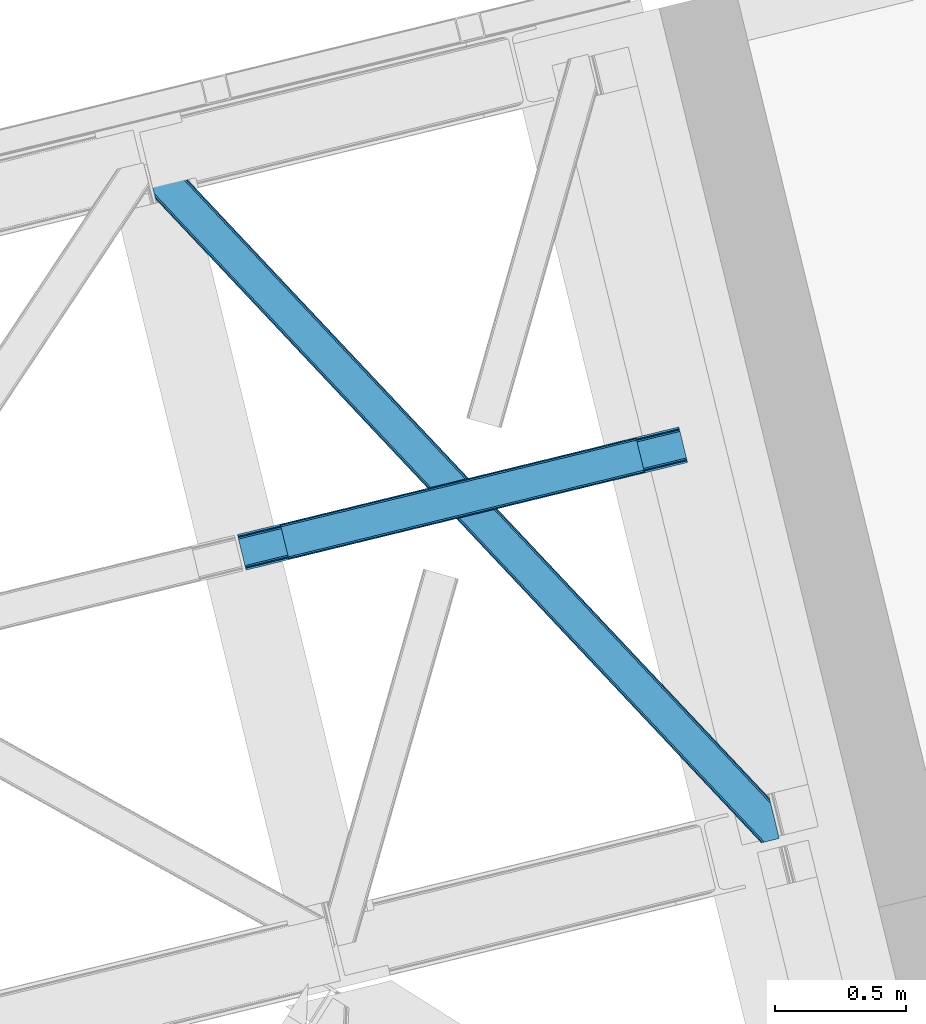
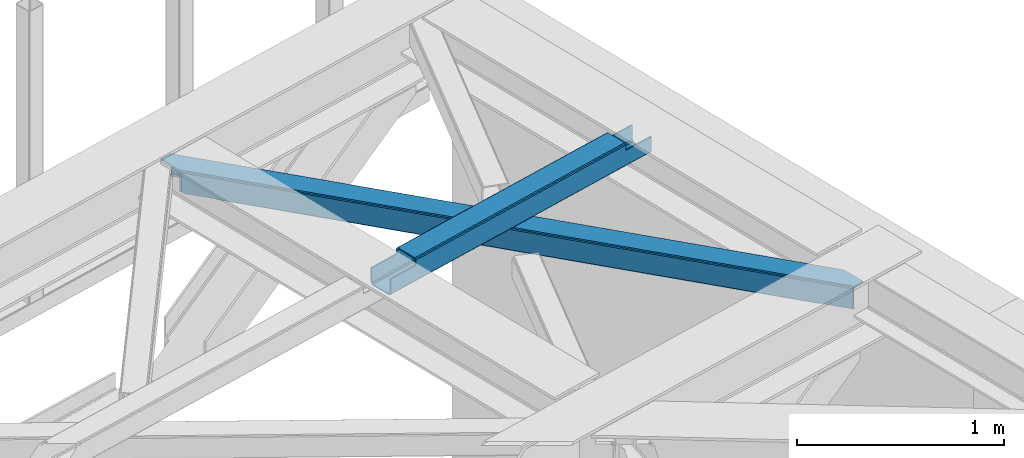
# One storey, part 61 of 66: 1 beam, 1 member.
"""IFC4 building model written with IfcOpenShell, lengths in millimetres."""

import ifcopenshell
import ifcopenshell.guid

model = None  # the IFC model being written
_history = None  # IfcOwnerHistory: only IFC2X3 demands one
_inside = {}  # id of a spatial element -> (the spatial element, [elements in it])
_under = {}  # id of a project, library or spatial element -> (it, [spatial elements below it])
_declared = {}  # id of a project -> (the project, [libraries it declares])
_typed = {}  # id of a type object -> (the type object, [elements of that type])
_made_of = {}  # id of a material, layer set ... -> (it, [elements and type objects made of it])


def new_model(schema):
    """Start an empty IFC model of exactly this schema.

    Asked for "IFC4X3", IfcOpenShell would pick the latest addendum, in which some entities
    have other attributes; the version numbers below select the first issue.
    IFC2X3 requires an IfcOwnerHistory on every rooted entity: one is made here for all.
    """
    global model, _history
    if schema == "IFC4X3":
        model = ifcopenshell.file(schema_version=(4, 3, 0, 0))
    else:
        model = ifcopenshell.file(schema=schema)
    _inside.clear()
    _under.clear()
    _declared.clear()
    _typed.clear()
    _made_of.clear()
    _history = None
    if model.schema == "IFC2X3":
        org = make("IfcOrganization", Name="unknown")
        user = make(
            "IfcPersonAndOrganization",
            ThePerson=make("IfcPerson", FamilyName="unknown"),
            TheOrganization=org,
        )
        app = make(
            "IfcApplication",
            ApplicationDeveloper=org,
            Version="unknown",
            ApplicationFullName="unknown",
            ApplicationIdentifier="unknown",
        )
        _history = make(
            "IfcOwnerHistory",
            OwningUser=user,
            OwningApplication=app,
            ChangeAction="ADDED",
            CreationDate=0,
        )
    return model


def make(cls, **values):
    """One entity of the class cls with the attributes given. An attribute that is None is left unset."""
    return model.create_entity(
        cls, **{name: value for name, value in values.items() if value is not None}
    )


def entity(cls, *values):
    """Any entity or typed value of the class cls, its attributes in the order of the schema. None: left unset."""
    e = model.create_entity(cls)
    for i, value in enumerate(values):
        if value is not None:
            e[i] = value
    return e


def rooted(cls, **values):
    """An entity with a GlobalId (a new one), such as an element, a storey or a relation."""
    return make(cls, GlobalId=ifcopenshell.guid.new(), OwnerHistory=_history, **values)


def si_unit(unit_type, name, prefix=None):
    """IfcSIUnit, for example si_unit("LENGTHUNIT", "METRE", prefix="MILLI")."""
    return make("IfcSIUnit", UnitType=unit_type, Prefix=prefix, Name=name)


def converted_unit(unit_type, name, factor, base, dimensions=None, offset=None):
    """IfcConversionBasedUnit, such as the inch: factor (a typed value) times the base unit."""
    return make(
        "IfcConversionBasedUnit"
        if offset is None
        else "IfcConversionBasedUnitWithOffset",
        ConversionOffset=offset,
        Dimensions=None
        if dimensions is None
        else entity("IfcDimensionalExponents", *dimensions),
        UnitType=unit_type,
        Name=name,
        ConversionFactor=make(
            "IfcMeasureWithUnit", ValueComponent=factor, UnitComponent=base
        ),
    )


def derived_unit(unit_type, elements):
    """IfcDerivedUnit: a product of units, each with its exponent."""
    return make(
        "IfcDerivedUnit",
        Elements=[
            make("IfcDerivedUnitElement", Unit=unit, Exponent=power)
            for unit, power in elements
        ],
        UnitType=unit_type,
    )


def assignment(units):
    """IfcUnitAssignment: the units of a project."""
    return None if units is None else make("IfcUnitAssignment", Units=units)


def point(xyz):
    """IfcCartesianPoint."""
    return None if xyz is None else make("IfcCartesianPoint", Coordinates=xyz)


def direction(xyz):
    """IfcDirection."""
    return None if xyz is None else make("IfcDirection", DirectionRatios=xyz)


def frame(location, z_axis=None, x_axis=None):
    """IfcAxis2Placement3D, a coordinate frame: its origin and axes. An axis left out is left unset."""
    return make(
        "IfcAxis2Placement3D",
        Location=point(location),
        Axis=direction(z_axis),
        RefDirection=direction(x_axis),
    )


def origin():
    """The frame at (0, 0, 0) with its axes left unset."""
    return frame((0.0, 0.0, 0.0))


def place(relative_to, where):
    """IfcLocalPlacement: puts the frame where relative to a parent placement (None: the world)."""
    return make(
        "IfcLocalPlacement", PlacementRelTo=relative_to, RelativePlacement=where
    )


def context(
    kind, dimensions, precision=None, world=None, true_north=None, identifier=None
):
    """IfcGeometricRepresentationContext, for example the 3D "Model" context."""
    return make(
        "IfcGeometricRepresentationContext",
        ContextIdentifier=identifier,
        ContextType=kind,
        CoordinateSpaceDimension=dimensions,
        Precision=precision,
        WorldCoordinateSystem=world,
        TrueNorth=true_north,
    )


def subcontext(parent, identifier, kind, view, scale=None):
    """IfcGeometricRepresentationSubContext, for example "Body" below "Model"."""
    return make(
        "IfcGeometricRepresentationSubContext",
        ContextIdentifier=identifier,
        ContextType=kind,
        ParentContext=parent,
        TargetScale=scale,
        TargetView=view,
    )


def project(units=None, contexts=None):
    """IfcProject with its units and contexts."""
    return rooted(
        "IfcProject",
        Name="project",
        RepresentationContexts=contexts,
        UnitsInContext=assignment(units),
    )


def spatial(cls, under=None, at=None, **own):
    """A site, building, storey or space (cls), placed at a placement, below another one or the project."""
    s = rooted(cls, ObjectPlacement=at, **own)
    if under is not None:
        _under.setdefault(under.id(), (under, []))[1].append(s)
    return s


def point_list(points):
    """IfcCartesianPointList2D or 3D."""
    cls = (
        "IfcCartesianPointList2D" if len(points[0]) == 2 else "IfcCartesianPointList3D"
    )
    return make(cls, CoordList=points)


def triangles(points, corners, closed=None, point_numbers=None):
    """IfcTriangulatedFaceSet: each triangle names its three corners, points numbered from 1."""
    return make(
        "IfcTriangulatedFaceSet",
        Coordinates=point_list(points),
        Closed=closed,
        CoordIndex=corners,
        PnIndex=point_numbers,
    )


def polygons(points, faces, closed=None, point_numbers=None):
    """IfcPolygonalFaceSet: a face is its outer loop, then its inner loops; points numbered from 1."""
    made = []
    for loops in faces:
        if len(loops) == 1:
            made.append(make("IfcIndexedPolygonalFace", CoordIndex=loops[0]))
        else:
            made.append(
                make(
                    "IfcIndexedPolygonalFaceWithVoids",
                    CoordIndex=loops[0],
                    InnerCoordIndices=loops[1:],
                )
            )
    return make(
        "IfcPolygonalFaceSet",
        Coordinates=point_list(points),
        Closed=closed,
        Faces=made,
        PnIndex=point_numbers,
    )


def shape(context_of_items, identifier, shape_type, items):
    """IfcShapeRepresentation: the items that make up one representation, for example the "Body"."""
    return make(
        "IfcShapeRepresentation",
        ContextOfItems=context_of_items,
        RepresentationIdentifier=identifier,
        RepresentationType=shape_type,
        Items=items,
    )


def material(Name=None, Category=None):
    """IfcMaterial."""
    return make("IfcMaterial", Name=Name, Category=Category)


def made_of(thing, what):
    """Note that an element or type object is made of a material, layer set ...; save() writes the relation."""
    if what is not None:
        _made_of.setdefault(what.id(), (what, []))[1].append(thing)
    return thing


def type_object(cls, material=None, **own):
    """A type object (cls), such as IfcWallType, which elements share."""
    return made_of(rooted(cls, **own), material)


def element(
    cls,
    number,
    at=None,
    inside=None,
    cuts=None,
    type_object=None,
    material=None,
    context=None,
    identifier="Body",
    shape_type=None,
    held_by="IfcProductDefinitionShape",
    body=None,
    shapes=None,
    **own,
):
    """One element of the class cls, such as IfcWall. Its Tag is "e" and its number.

    at: its placement. inside: the storey or other place that contains it. cuts: it is an
    opening in that element (IfcRelVoidsElement). A single representation is given by context,
    identifier, shape_type and body (its items); several are given by shapes. held_by: the class
    of the entity that holds the representations. save() writes the other relations.
    """
    e = rooted(cls, Tag="e%d" % number, ObjectPlacement=at, **own)
    if body is not None:
        shapes = [shape(context, identifier, shape_type, body)]
    if shapes is not None:
        e.Representation = make(held_by, Representations=shapes)
    if inside is not None:
        _inside.setdefault(inside.id(), (inside, []))[1].append(e)
    if cuts is not None:
        rooted(
            "IfcRelVoidsElement", RelatingBuildingElement=cuts, RelatedOpeningElement=e
        )
    if type_object is not None:
        _typed.setdefault(type_object.id(), (type_object, []))[1].append(e)
    return made_of(e, material)


def aggregate(whole, parts):
    """IfcRelAggregates: a whole, such as a stair, and the parts it consists of."""
    return rooted("IfcRelAggregates", RelatingObject=whole, RelatedObjects=parts)


def save(model, path):
    """Write the relations noted so far, then the file.

    IfcRelAggregates (storeys below a building ...), IfcRelContainedInSpatialStructure (elements
    in a storey), IfcRelDefinesByType, IfcRelAssociatesMaterial and IfcRelDeclares: one each for
    every whole, place, type object, material and project.
    """
    for whole, parts in _under.values():
        aggregate(whole, parts)
    for where, things in _inside.values():
        rooted(
            "IfcRelContainedInSpatialStructure",
            RelatedElements=things,
            RelatingStructure=where,
        )
    for kind, things in _typed.values():
        rooted("IfcRelDefinesByType", RelatedObjects=things, RelatingType=kind)
    for what, things in _made_of.values():
        rooted("IfcRelAssociatesMaterial", RelatedObjects=things, RelatingMaterial=what)
    for by, libraries in _declared.values():
        rooted("IfcRelDeclares", RelatingContext=by, RelatedDefinitions=libraries)
    model.write(path)


model = new_model("IFC4")

# Units and contexts
model_context = context("Model", 3, precision=0.01, world=origin(), true_north=direction((6.12303176911189e-17, 1.0)))
plan_context = context("Plan", 3, precision=0.01, world=origin(), true_north=direction((6.12303176911189e-17, 1.0)))
body_context = subcontext(model_context, "Body", "Model", "MODEL_VIEW")
ifc_project = project(units=[si_unit("LENGTHUNIT", "METRE", prefix="MILLI"), si_unit("AREAUNIT", "SQUARE_METRE"), si_unit("VOLUMEUNIT", "CUBIC_METRE"), converted_unit("PLANEANGLEUNIT", "DEGREE", entity("IfcRatioMeasure", 0.0174532925199433), si_unit("PLANEANGLEUNIT", "RADIAN"), dimensions=[0, 0, 0, 0, 0, 0, 0]), si_unit("MASSUNIT", "GRAM", prefix="KILO"), derived_unit("MASSDENSITYUNIT", [(si_unit("MASSUNIT", "GRAM", prefix="KILO"), 1), (si_unit("LENGTHUNIT", "METRE"), -3)]), derived_unit("MOMENTOFINERTIAUNIT", [(si_unit("LENGTHUNIT", "METRE"), 4)]), si_unit("TIMEUNIT", "SECOND"), si_unit("FREQUENCYUNIT", "HERTZ"), si_unit("THERMODYNAMICTEMPERATUREUNIT", "DEGREE_CELSIUS"), derived_unit("THERMALTRANSMITTANCEUNIT", [(si_unit("MASSUNIT", "GRAM", prefix="KILO"), 1), (si_unit("THERMODYNAMICTEMPERATUREUNIT", "KELVIN"), -1), (si_unit("TIMEUNIT", "SECOND"), -3)]), derived_unit("VOLUMETRICFLOWRATEUNIT", [(si_unit("LENGTHUNIT", "METRE"), 3), (si_unit("TIMEUNIT", "SECOND"), -1)]), derived_unit("MASSFLOWRATEUNIT", [(si_unit("MASSUNIT", "GRAM", prefix="KILO"), 1), (si_unit("TIMEUNIT", "SECOND"), -1)]), derived_unit("ROTATIONALFREQUENCYUNIT", [(si_unit("TIMEUNIT", "SECOND"), -1)]), si_unit("ELECTRICCURRENTUNIT", "AMPERE"), si_unit("ELECTRICVOLTAGEUNIT", "VOLT"), si_unit("POWERUNIT", "WATT"), si_unit("FORCEUNIT", "NEWTON", prefix="KILO"), si_unit("ILLUMINANCEUNIT", "LUX"), si_unit("LUMINOUSFLUXUNIT", "LUMEN"), si_unit("LUMINOUSINTENSITYUNIT", "CANDELA"), derived_unit("USERDEFINED", [(si_unit("MASSUNIT", "GRAM", prefix="KILO"), -1), (si_unit("LENGTHUNIT", "METRE"), -2), (si_unit("TIMEUNIT", "SECOND"), 3), (si_unit("LUMINOUSFLUXUNIT", "LUMEN"), 1)]), derived_unit("LINEARVELOCITYUNIT", [(si_unit("LENGTHUNIT", "METRE"), 1), (si_unit("TIMEUNIT", "SECOND"), -1)]), si_unit("PRESSUREUNIT", "PASCAL"), derived_unit("USERDEFINED", [(si_unit("LENGTHUNIT", "METRE"), -2), (si_unit("MASSUNIT", "GRAM", prefix="KILO"), 1), (si_unit("TIMEUNIT", "SECOND"), -2)]), derived_unit("LINEARFORCEUNIT", [(si_unit("MASSUNIT", "GRAM", prefix="KILO"), 1), (si_unit("LENGTHUNIT", "METRE"), 1), (si_unit("TIMEUNIT", "SECOND"), -2), (si_unit("LENGTHUNIT", "METRE"), -1)]), derived_unit("PLANARFORCEUNIT", [(si_unit("MASSUNIT", "GRAM", prefix="KILO"), 1), (si_unit("LENGTHUNIT", "METRE"), 1), (si_unit("TIMEUNIT", "SECOND"), -2), (si_unit("LENGTHUNIT", "METRE"), -2)])], contexts=[model_context, plan_context])

# Site, building, storey
site_placement = place(None, origin())
site = spatial("IfcSite", under=ifc_project, at=site_placement, CompositionType="ELEMENT")
building_placement = place(site_placement, origin())
building = spatial("IfcBuilding", under=site, at=building_placement, CompositionType="ELEMENT")
storey_placement = place(building_placement, frame((0.0, 0.0, 19800.0)))
storey = spatial("IfcBuildingStorey", under=building, at=storey_placement, Name="06", CompositionType="ELEMENT", Elevation=19800.0)

# Beam
ifc_material = material(Name="Metal painted (White)")
beam_type = type_object("IfcBeamType", PredefinedType="BEAM")
beam_placement = place(storey_placement, frame((-2546.54, 18519.2, 3967.02)))
element("IfcBeam", 1, at=beam_placement, inside=storey, type_object=beam_type, material=ifc_material, ObjectType="Steel Beam", PredefinedType="BEAM", context=body_context, shape_type="Tessellation", body=[
    polygons([(31.1823923917663, 8.09507685196325, 17.8030399336114), (31.4978703677219, 6.80086440699217, 24.4999999999988), (1720.05534741759, 418.404614024197, 24.4999999999988), (1719.73986944163, 419.698826469164, 17.8030399336114), (30.2839871259127, 11.7806820741907, 12.1256313292298), (1718.84146417578, 423.384431691391, 12.1256313292298), (28.9394286278299, 17.2965800886753, 8.33210818105214), (1717.4969056777, 428.90032970588, 8.33210818105214), (27.3534137403943, 23.8030254244683, 7.00000000000274), (1715.91089079026, 435.406775041673, 7.00000000000274), (4.21622439083855, 118.720708051134, 8.33210818105214), (5.80223927827368, 112.214262715343, 7.00000000000274), (1694.35971632814, 523.818012332546, 7.00000000000274), (1692.77370144071, 530.324457668336, 8.33210818105214), (2.87166589275528, 124.236606065622, 12.1256313292342), (1691.42914294262, 535.840355682825, 12.1256313292342), (1.97326062690218, 127.922211287848, 17.8030399336114), (1690.53073767677, 539.525960905051, 17.8030399336114), (1.65778265093897, 129.216423732819, 24.4999999999988), (1690.2152597008, 540.820173350022, 24.4999999999988), (33.1556530186512, 2.16573425859679e-12, 17.5000000000004), (33.155653018649, 0.0, 99.499999999999), (31.4978703677154, 6.80086440699217, 99.499999999999), (1.65778265093518, 129.216423732817, 99.499999999999), (2.70716782324598e-12, 136.017288139807, 99.499999999999), (3.79003495254437e-12, 136.017288139809, 17.5000000000004), (0.315477975962668, 134.72307569484, 10.803039933613), (1.21388324181576, 131.037470472615, 5.12563132923143), (2.55844173989904, 125.521572458126, 1.33210818105373), (4.14445662733417, 119.015127122333, 0.0), (29.0111963913197, 17.0021610174783, 0.0), (30.5972112787548, 10.4957156816875, 1.33210818105373), (31.9417697768392, 4.97981766719418, 5.12563132923576), (32.8401750426917, 1.29421244497107, 10.803039933613), (1688.55747704987, 547.62103775701, 17.5000000000004), (1688.55747704987, 547.62103775701, 99.499999999999), (1690.2152597008, 540.820173350022, 99.499999999999), (1720.05534741758, 418.404614024193, 99.499999999999), (1721.71313006851, 411.603749617205, 99.499999999999), (1721.71313006851, 411.603749617205, 17.5000000000004), (1721.39765209255, 412.897962062172, 10.803039933613), (1720.4992468267, 416.583567284397, 5.12563132923576), (1719.15468832862, 422.099465298888, 1.33210818105373), (1717.56867344118, 428.605910634677, 0.0), (1692.7019336772, 530.618876739533, 0.0), (1691.11591878976, 537.125322075326, 1.33210818105373), (1689.77136029168, 542.641220089815, 5.12563132923143), (1688.87295502583, 546.326825312043, 10.803039933613), (1555.87153982994, 378.383074424505, 115.5000123926), (1555.92790791481, 378.396813643123, 100.117303289864), (1556.83460164982, 378.617830401818, 99.499999999999), (194.718606580802, 46.5876811586757, 99.5063429816656), (195.631369831917, 46.8101414945073, 100.117301735448), (195.69016819363, 46.824474122359, 115.5), (1558.49238430075, 371.81696599483, 99.499999999999), (1557.58582420851, 371.595981821318, 100.117303484932), (1557.52624144083, 371.581458788976, 122.500007895425), (197.345360928056, 40.0229783796067, 122.500002534479), (197.338587096744, 40.0213271441522, 100.500009163303), (196.748205195733, 39.8773799905108, 99.5697919021647), (1526.99452348773, 501.033356598336, 99.5063429816656), (1526.08541462826, 500.811786435622, 100.117299778624), (1526.02904654339, 500.798047217008, 115.50000888136), (165.85008047685, 169.240033448186, 115.5), (165.840462203346, 169.237688832046, 100.50000941238), (165.250325295043, 169.093836777335, 99.5761204674868), (1524.96492487281, 507.743657766505, 99.5697919021647), (163.22074576778, 175.804071762184, 99.499999999999), (164.133244938524, 176.026503182401, 100.117301984524), (164.18943998764, 176.04020120897, 122.500002796667), (1524.36791556689, 507.598095225085, 122.500003994045), (1524.37801885572, 507.600558639654, 100.500018741102), (1524.68002972126, 506.303062602923, 129.196959150505), (1525.57336524685, 502.616221261231, 134.874360354937), (1526.91465625092, 497.099526556424, 138.667878733795), (1528.49970333692, 490.592845248349, 139.999985502214), (1553.37045238386, 388.580856699036, 139.999991354279), (1554.95794650144, 382.074772033634, 138.667885332354), (1556.30620606188, 376.559776423407, 134.874367586349), (1557.20997076909, 372.875477956454, 129.196966804773), (1555.55835019824, 379.677844820524, 122.196975799125), (1554.65458549103, 383.362143287481, 127.874376580702), (1553.3063259306, 388.877138897706, 131.667894326702), (1551.71883181301, 395.383223563109, 133.000000348631), (1530.164182639, 483.793613639179, 132.999995276841), (1528.579135553, 490.300294947254, 131.667888508414), (1527.23784454893, 495.816989652061, 127.874370129564), (1526.34450902334, 499.503830993753, 122.196968925133), (164.878528418712, 169.003207355194, 99.499999999999), (193.131726453735, 57.3201898040421, 131.667891818946), (191.5457115663, 63.826635139835, 133.0), (194.476284951818, 51.8042917895531, 127.874368670764), (195.374690217671, 48.1186865673279, 122.196960066391), (169.994537104178, 152.237872430709, 133.0), (166.165558452807, 167.945821003219, 122.196960066391), (167.06396371866, 164.260215780991, 127.874368670764), (168.408522216743, 158.744317766505, 131.667891818946), (197.031411944076, 41.3175635421181, 129.196961104604), (196.136488323068, 45.0040174739068, 134.874366301861), (194.794244157318, 50.5204796458773, 138.667887185257), (193.209023953587, 57.0271186992037, 139.999994588639), (168.341882306944, 159.039986838394, 139.999994981919), (166.755021471193, 165.546225960036, 138.667887628704), (165.408105180737, 171.061549222932, 134.874366787843), (164.50618923097, 174.746298656831, 129.196961619)], [[[1, 2, 3, 4]], [[5, 1, 4, 6]], [[7, 5, 6, 8]], [[9, 7, 8, 10]], [[11, 12, 13, 14]], [[15, 11, 14, 16]], [[17, 15, 16, 18]], [[19, 17, 18, 20]], [[12, 9, 10, 13]], [[21, 22, 23, 2, 1, 5, 7, 9, 12, 11, 15, 17, 19, 24, 25, 26, 27, 28, 29, 30, 31, 32, 33, 34]], [[35, 36, 37, 20, 18, 16, 14, 13, 10, 8, 6, 4, 3, 38, 39, 40, 41, 42, 43, 44, 45, 46, 47, 48]], [[49, 50, 51, 38, 3, 2, 23, 52, 53, 54]], [[55, 39, 38, 51]], [[39, 55, 56, 57, 58, 59, 60, 22, 21, 40]], [[32, 31, 44, 43]], [[33, 32, 43, 42]], [[34, 33, 42, 41]], [[21, 34, 41, 40]], [[31, 30, 45, 44]], [[27, 26, 35, 48]], [[28, 27, 48, 47]], [[29, 28, 47, 46]], [[30, 29, 46, 45]], [[20, 37, 61, 62, 63, 64, 65, 66, 24, 19]], [[67, 36, 35, 26, 25, 68, 69, 70, 71, 72]], [[36, 67, 61, 37]], [[72, 71, 73, 74, 75, 76, 77, 78, 79, 80, 57, 56, 50, 49, 81, 82, 83, 84, 85, 86, 87, 88, 63, 62]], [[60, 52, 23, 22]], [[25, 24, 89, 68]], [[90, 91, 84, 83]], [[92, 90, 83, 82]], [[93, 92, 82, 81]], [[54, 93, 81, 49]], [[94, 85, 84, 91]], [[95, 64, 63, 88]], [[96, 95, 88, 87]], [[97, 96, 87, 86]], [[94, 97, 86, 85]], [[65, 64, 95, 96, 97, 94, 91, 90, 92, 93, 54, 53, 59, 58, 98, 99, 100, 101, 102, 103, 104, 105, 70, 69]], [[98, 58, 57, 80]], [[99, 98, 80, 79]], [[100, 99, 79, 78]], [[101, 100, 78, 77]], [[77, 76, 102, 101]], [[103, 102, 76, 75]], [[104, 103, 75, 74]], [[105, 104, 74, 73]], [[70, 105, 73, 71]]], closed=False),
])

# Member
member_type = type_object("IfcMemberType", PredefinedType="BRACE")
member_placement = place(storey_placement, frame((-2893.85, 17476.17, 3823.02)))
element("IfcMember", 2, at=member_placement, inside=storey, type_object=member_type, ObjectType="Steel Horizontal Brace", PredefinedType="BRACE", context=body_context, shape_type="Tessellation", body=[
    triangles([(2390.20879182816, 136.983499145506, 139.998431396481), (2386.99318141937, 150.175717163085, 138.668280029295), (56.5227127075195, 2617.59836425781, 139.998431396481), (64.0010353088378, 2619.42150878906, 138.668280029295), (2384.26711235046, 161.358755493166, 134.873162841795), (70.3451248168944, 2620.96792602539, 134.873162841795), (2382.44560289383, 168.831555175781, 129.196765136716), (74.5788780212401, 2622.00042114258, 129.196765136716), (2381.80599803925, 171.455813598634, 122.499499511716), (76.0700660705566, 2622.36318969727, 122.499499511716), (2006.64328708649, 570.234960937501, 17.4989318847656), (2381.80599803925, 171.455813598634, 17.4989318847656), (1617.6124546051, 983.763208007811, 17.4989318847656), (1228.57718925476, 1397.2902923584, 17.4989318847656), (450.510873413086, 2224.3456237793, 17.4989318847656), (76.0700660705566, 2622.36318969727, 17.4989318847656), (839.546284103394, 1810.81853942871, 17.4989318847656), (26.1158477783201, 2496.68248901367, 139.998431396481), (0.0, 2603.82013549805, 139.998431396481), (2370.43223733902, 4.76366271972802, 139.998431396481), (2419.52200984955, 16.7303741455071, 139.998431396481), (2350.88942584991, 0.0, 122.499499511716), (2352.37603569031, 0.362768554688955, 129.196765136716), (34.5188232421874, 2462.2125, 122.499499511716), (33.8790367126462, 2464.83559570312, 129.196765136716), (2356.61443977356, 1.395263671875, 134.873162841795), (32.0576362609863, 2472.30723266601, 134.873162841795), (2362.95402374268, 2.94051818847583, 138.668280029295), (29.3316398620605, 2483.49259643555, 138.668280029295), (1193.06046180725, 1230.72371520996, 17.4989318847656), (1583.89125709534, 815.290933227538, 17.4989318847656), (1974.7174741745, 399.856988525389, 17.4989318847656), (2350.88942584991, 0.0, 17.4989318847656), (802.234317398071, 1646.15765991211, 17.4989318847656), (411.408027648926, 2061.59276733398, 17.4989318847656), (34.5188232421874, 2462.2125, 17.4989318847656), (2364.4315861702, 3.30096130371021, 127.873590087889), (2370.77113380432, 4.84621582031104, 131.666381835938), (2360.19314575195, 2.26730346679688, 122.19719238281), (2378.2538892746, 6.67052307129052, 132.998858642575), (2419.52200984955, 16.7303741455071, 132.998858642575), (2358.70653591156, 1.90569763183521, 115.49992675781), (2358.70653591156, 1.90569763183521, 24.4985046386719), (2360.19314575195, 2.26730346679688, 17.8035644531228), (2352.67877883911, 0.436019897460938, 10.8691040039048), (2353.04928674698, 0.526712036131357, 9.49942016601563), (2364.4315861702, 3.30096130371021, 12.1248413085923), (2368.18651685715, 4.21602172851635, 9.49942016601563), (1982.47063465118, 401.827798461913, 24.4985046386719), (1588.94283828735, 820.135986328125, 24.4985046386719), (1195.4104637146, 1238.44417419434, 24.4985046386719), (31.1576911926268, 2476.00003051758, 115.49992675781), (408.350074768066, 2075.05938720703, 24.4985046386719), (31.1576911926268, 2476.00003051758, 24.4985046386719), (801.882594680786, 1656.75236206055, 24.4985046386719), (25.9705078124998, 2497.28012695313, 131.666381835938), (22.7547157287595, 2510.4723449707, 132.998858642575), (28.6965042114257, 2486.09708862305, 127.873590087889), (30.517904663086, 2478.6231262207, 122.19719238281), (30.3873893737791, 2479.16030273437, 17.8710021972656), (34.5051612854004, 2462.26831054688, 16.4989929199219), (30.22809677124, 2479.8137512207, 16.4989929199219), (0.0, 2603.82013549805, 132.998858642575), (48.7057479858399, 2615.6938293457, 132.998858642575), (2393.56992387772, 123.194805908202, 132.998858642575), (2385.16713008881, 157.66712036133, 115.49992675781), (2385.80673494339, 155.042861938477, 122.19719238281), (66.7619132995605, 2620.09588623047, 122.19719238281), (68.2484504699705, 2620.4563293457, 115.49992675781), (2387.62824440002, 147.570062255858, 127.873590087889), (62.527869415283, 2619.06339111328, 127.873590087889), (2390.35431346893, 136.387023925781, 131.666381835938), (56.1837799072264, 2617.51697387695, 131.666381835938), (1226.23169288635, 1389.57215881348, 24.4985046386719), (1617.96868286133, 973.170831298827, 24.4985046386719), (2009.70560016632, 556.76950378418, 24.4985046386719), (2385.16713008881, 157.66712036133, 24.4985046386719), (834.490197372436, 1805.9723236084, 24.4985046386719), (442.753207397461, 2222.37365112305, 24.4985046386719), (68.2484504699705, 2620.4563293457, 24.4985046386719), (66.7619132995605, 2620.09588623047, 17.8035644531228), (74.2762802124021, 2621.92600708008, 10.8691040039048), (73.9056632995603, 2621.83764038086, 9.49942016601563), (62.527869415283, 2619.06339111328, 12.1248413085923), (58.7728660583493, 2618.14716796875, 9.49942016601563), (2385.9372502327, 154.508010864258, 17.8710021972656), (2386.09654283524, 153.854562377928, 16.4989929199219), (2381.81973266602, 171.398840332033, 16.4989929199219), (41.7939605712891, 2456.42215576172, 10.8016662597656), (36.8073463439941, 2482.3787109375, 9.49942016601563), (34.7757843017575, 2479.63701782226, 12.1248413085923), (43.3136352539063, 2455.68731689453, 9.49942016601563), (170.418958282471, 2340.35482177734, 9.49942016601563), (155.286451721192, 2336.66434936523, 9.49942016601563), (180.780244445801, 2508.2352722168, 9.49942016601563), (187.286533355713, 2481.54155273438, 9.49942016601563), (181.188068389893, 2507.60275268555, 9.25292358398292), (187.878357696533, 2480.72532348633, 9.42268066406177), (181.610426330567, 2506.94930419922, 8.99945068359375), (188.450415802002, 2479.24401855469, 9.11572265625), (182.028424072265, 2506.29585571289, 8.74597778320094), (189.028287506103, 2477.75573730469, 8.80643920898365), (182.436248016357, 2505.66333618164, 8.49948120117188), (189.60005493164, 2476.27443237305, 8.49948120117188), (2381.54910964966, 154.028970336913, 12.1248413085923), (2374.53078804016, 177.24383239746, 10.8016662597656), (2379.51751127243, 151.288439941407, 9.49942016601563), (2373.01111335754, 177.979833984376, 9.49942016601563), (2233.21012630463, 306.80569152832, 9.49942016601563), (2248.34285087585, 310.495001220705, 9.49942016601563), (2005.67379684448, 569.32222595215, 10.8016662597656), (2002.91328220367, 566.723547363283, 5.12526855468604), (2244.78223972321, 309.626449584961, 5.12526855468604), (449.541455841064, 2223.43405151367, 10.8016662597656), (446.776508331299, 2220.83421020508, 5.12526855468604), (183.700996398926, 2500.47295532226, 5.12526855468604), (442.640714263916, 2216.94375, 1.33247680663771), (186.427283477783, 2489.28991699219, 1.33247680663771), (437.765721130371, 2212.35565795899, 0.0), (189.642784881592, 2476.09769897461, 0.0), (2238.43815021515, 308.080032348633, 1.33247680663771), (2230.95990028381, 306.256887817384, 0.0), (1998.77770614624, 562.833087158204, 1.33247680663771), (1993.89820747375, 558.24383239746, 0.0), (1616.64303703308, 982.850473022459, 10.8016662597656), (1227.60762634277, 1396.37755737305, 10.8016662597656), (838.572215652466, 1809.90464172363, 10.8016662597656), (1613.87794418335, 980.250631713869, 5.12526855468604), (1224.84253349304, 1393.77771606445, 5.12526855468604), (835.811773681641, 1807.30596313476, 5.12526855468604), (1609.74229545593, 976.36017150879, 1.33247680663771), (1220.71153564453, 1389.8884185791, 1.33247680663771), (831.676124954224, 1803.41666564941, 1.33247680663771), (1604.86730232239, 971.772079467773, 0.0), (1215.83203697205, 1385.29916381836, 0.0), (826.796626281738, 1798.82741088867, 0.0), (2008.73153171539, 555.855606079102, 17.8035644531228), (2005.9709444046, 553.256927490234, 12.1248413085923), (439.023202514648, 2218.86223754883, 12.1248413085923), (189.798298645019, 2475.46052856445, 8.4111145019524), (434.887699127197, 2214.97177734375, 8.33204956054396), (193.003916931152, 2462.31016845703, 6.99957275390625), (2001.83544101715, 549.366467285156, 8.33204956054396), (1996.95594234467, 544.777212524416, 6.99957275390625), (2223.14279022217, 304.352352905273, 6.99957275390625), (2230.46741580963, 306.137127685546, 8.81806640624927), (430.008055114746, 2210.38368530274, 6.99957275390625), (441.783789825439, 2221.45975341797, 17.8035644531228), (1610.09852371216, 965.767794799805, 8.33204956054396), (1605.21902503967, 961.178540039062, 6.99957275390625), (1213.4820350647, 1377.57986755371, 6.99957275390625), (1218.36153373718, 1382.16912231445, 8.33204956054396), (821.745045089722, 1793.98119506836, 6.99957275390625), (826.624543762207, 1798.5704498291, 8.33204956054396), (1614.23402709961, 969.658255004884, 12.1248413085923), (1222.49703712463, 1386.05958251953, 12.1248413085923), (830.760192489624, 1802.46091003418, 12.1248413085923), (1616.9946144104, 972.256933593751, 17.8035644531228), (1225.25762443542, 1388.6582611084, 17.8035644531228), (833.520634460449, 1805.05958862305, 17.8035644531228), (219.79792098999, 2352.39129638672, 0.0), (219.79792098999, 2352.39129638672, 6.99957275390625), (173.166464996338, 2341.02454833984, 8.81806640624927), (180.486367034912, 2342.80816040039, 6.99957275390625), (172.669402313232, 2340.90130004883, 0.0), (165.191079711914, 2339.08048095703, 1.33247680663771), (158.846990203857, 2337.5340637207, 5.12526855468604), (424.15317993164, 2073.5827331543, 0.0), (814.97932434082, 1658.14878845215, 0.0), (1205.81011962891, 1242.71600646973, 0.0), (1987.46262645721, 411.846954345703, 0.0), (1596.63640937805, 827.282061767579, 0.0), (2192.71020011902, 296.934201049804, 0.0), (2226.68196372986, 157.568289184572, 0.0), (421.095517730713, 2087.04935302735, 6.99957275390625), (814.627746963501, 1668.74349060059, 6.99957275390625), (1208.15561599731, 1250.43414001465, 6.99957275390625), (1995.22029247284, 413.820089721681, 6.99957275390625), (2192.71020011902, 296.934201049804, 6.99957275390625), (2223.3208316803, 171.356982421876, 6.99957275390625), (1601.68799057007, 832.127114868163, 6.99957275390625), (1975.68703708649, 400.768560791017, 10.8016662597656), (412.377445220947, 2062.50433959961, 10.8016662597656), (415.142683410645, 2065.1041809082, 5.12526855468604), (2235.13660755157, 126.065560913084, 9.25292358398292), (2234.7142496109, 126.717846679687, 8.99945068359375), (2235.54457683563, 125.433041381835, 9.49942016601563), (2234.29632453918, 127.372457885744, 8.74597778320094), (2233.88835525513, 128.004977416993, 8.49948120117188), (1978.45205726624, 403.368402099608, 5.12526855468604), (2232.62367954254, 133.193032836913, 5.12526855468604), (2229.89761047363, 144.376071166993, 1.33247680663771), (1982.58312778473, 407.257699584959, 1.33247680663771), (419.278186798096, 2068.99464111328, 1.33247680663771), (1591.75691070557, 822.692807006835, 1.33247680663771), (1200.93062095642, 1238.12675170898, 1.33247680663771), (810.104331207275, 1653.56069641113, 1.33247680663771), (1587.62126197815, 818.802346801756, 5.12526855468604), (1196.79511756897, 1234.2362915039, 5.12526855468604), (805.968827819824, 1649.67023620605, 5.12526855468604), (1584.86082000732, 816.203668212889, 10.8016662597656), (1194.03453025818, 1231.63761291504, 10.8016662597656), (803.203734970093, 1647.07039489746, 10.8016662597656), (1990.34079380035, 409.230834960938, 8.33204956054396), (2227.21637878418, 155.690496826173, 8.8831787109375), (2226.72454833984, 157.393881225587, 8.49948120117188), (1986.20521774292, 405.340374755859, 12.1248413085923), (2229.03814258575, 152.124435424805, 9.49942016601563), (2228.43301963806, 153.310409545898, 9.2947814941399), (2227.82150173187, 154.503359985352, 9.08781738280959), (2226.52637729645, 158.206622314454, 8.4111145019524), (416.220524597168, 2082.46126098633, 8.33204956054396), (412.084730529785, 2078.5731262207, 12.1248413085923), (409.319783020019, 2075.97328491211, 17.8035644531228), (1983.44470310211, 402.741696166991, 17.8035644531228), (1589.91240119934, 821.048721313477, 17.8035644531228), (1196.38002662659, 1239.35690917969, 17.8035644531228), (802.852157592773, 1657.6650970459, 17.8035644531228), (1592.67284317017, 823.647399902344, 12.1248413085923), (1199.14497413635, 1241.95675048828, 12.1248413085923), (805.612599563598, 1660.26377563476, 12.1248413085923), (1596.80849189758, 827.537860107423, 8.33204956054396), (1203.28062286377, 1245.84604797363, 8.33204956054396), (809.748248291015, 1664.15423583984, 8.33204956054396)], [[1, 2, 3], [4, 3, 2], [2, 5, 4], [6, 4, 5], [5, 7, 6], [8, 6, 7], [7, 9, 8], [10, 8, 9], [11, 9, 12], [9, 11, 13], [9, 14, 10], [14, 9, 13], [15, 16, 10], [17, 10, 14], [10, 17, 15], [3, 18, 1], [3, 19, 18], [20, 1, 18], [21, 1, 20], [22, 23, 24], [25, 24, 23], [23, 26, 25], [27, 25, 26], [26, 28, 27], [29, 27, 28], [28, 20, 29], [18, 29, 20], [30, 22, 24], [22, 31, 32], [30, 31, 22], [32, 33, 22], [34, 24, 35], [24, 34, 30], [36, 35, 24], [37, 38, 28], [26, 37, 28], [37, 26, 23], [39, 37, 23], [39, 23, 22], [38, 20, 28], [21, 40, 41], [21, 20, 40], [38, 40, 20], [39, 22, 42], [43, 33, 44], [22, 43, 42], [33, 45, 44], [22, 33, 43], [46, 47, 45], [47, 44, 45], [48, 47, 46], [49, 42, 43], [42, 49, 50], [42, 51, 52], [51, 42, 50], [53, 54, 52], [55, 52, 51], [52, 55, 53], [40, 38, 56], [56, 57, 40], [38, 37, 58], [58, 56, 38], [37, 39, 59], [59, 58, 37], [39, 42, 52], [52, 59, 39], [60, 61, 62], [24, 36, 54], [36, 60, 54], [54, 52, 24], [36, 61, 60], [59, 24, 52], [25, 24, 59], [27, 59, 58], [59, 27, 25], [58, 29, 27], [56, 29, 58], [56, 57, 18], [56, 18, 29], [57, 19, 18], [57, 63, 19], [57, 64, 65], [64, 57, 63], [65, 40, 57], [41, 40, 65], [66, 67, 68], [68, 69, 66], [67, 70, 71], [71, 68, 67], [70, 72, 73], [73, 71, 70], [72, 65, 64], [64, 73, 72], [74, 66, 69], [66, 75, 76], [74, 75, 66], [76, 77, 66], [78, 69, 79], [69, 78, 74], [80, 79, 69], [71, 73, 4], [6, 71, 4], [71, 6, 8], [68, 71, 8], [68, 8, 10], [73, 3, 4], [19, 64, 63], [19, 3, 64], [73, 64, 3], [68, 10, 69], [80, 16, 81], [10, 80, 69], [16, 82, 81], [10, 16, 80], [83, 84, 82], [84, 81, 82], [85, 84, 83], [70, 5, 2], [65, 72, 1], [72, 70, 2], [86, 87, 88], [41, 65, 21], [1, 21, 65], [72, 2, 1], [86, 12, 77], [9, 66, 77], [77, 12, 9], [86, 88, 12], [9, 67, 66], [67, 5, 70], [5, 67, 7], [9, 7, 67], [89, 90, 91], [89, 92, 90], [91, 61, 89], [62, 61, 91], [92, 90, 93], [93, 94, 92], [85, 83, 95], [95, 96, 85], [97, 98, 96], [99, 100, 98], [101, 102, 100], [103, 104, 102], [102, 101, 103], [100, 99, 101], [98, 97, 99], [96, 95, 97], [88, 105, 106], [105, 88, 87], [107, 106, 105], [107, 108, 106], [109, 110, 108], [108, 107, 109], [12, 88, 106], [111, 106, 110], [110, 112, 111], [110, 113, 112], [106, 108, 110], [114, 101, 99], [101, 114, 103], [114, 97, 95], [97, 114, 99], [95, 82, 114], [95, 83, 82], [114, 115, 116], [116, 103, 114], [114, 82, 16], [16, 15, 114], [115, 117, 118], [118, 116, 115], [117, 119, 120], [120, 118, 117], [121, 122, 123], [124, 123, 122], [113, 121, 112], [123, 112, 121], [12, 106, 11], [111, 11, 106], [11, 111, 125], [125, 13, 11], [13, 125, 14], [126, 14, 125], [14, 126, 17], [127, 17, 126], [17, 127, 15], [114, 15, 127], [111, 112, 125], [128, 125, 112], [125, 128, 126], [129, 126, 128], [126, 129, 130], [130, 127, 126], [127, 130, 115], [115, 114, 127], [112, 123, 131], [131, 128, 112], [128, 131, 132], [132, 129, 128], [129, 132, 133], [133, 130, 129], [130, 133, 117], [117, 115, 130], [123, 124, 131], [134, 131, 124], [131, 134, 132], [135, 132, 134], [132, 135, 133], [136, 133, 135], [133, 136, 119], [119, 117, 133], [137, 138, 105], [105, 87, 137], [137, 86, 77], [139, 104, 140], [102, 139, 100], [102, 104, 139], [98, 100, 139], [96, 139, 84], [84, 85, 96], [96, 98, 139], [141, 140, 142], [143, 144, 145], [138, 143, 146], [146, 109, 138], [107, 105, 109], [138, 109, 105], [145, 146, 143], [142, 147, 141], [140, 141, 139], [139, 148, 81], [81, 84, 139], [148, 79, 80], [80, 81, 148], [77, 76, 137], [87, 86, 137], [144, 143, 149], [149, 150, 144], [150, 149, 151], [152, 151, 149], [151, 152, 153], [154, 153, 152], [153, 154, 147], [141, 147, 154], [143, 138, 149], [155, 149, 138], [149, 155, 152], [156, 152, 155], [152, 156, 157], [157, 154, 152], [154, 157, 141], [139, 141, 157], [138, 137, 158], [158, 155, 138], [155, 158, 159], [159, 156, 155], [156, 159, 157], [160, 157, 159], [157, 160, 148], [148, 139, 157], [137, 76, 75], [75, 158, 137], [158, 75, 74], [74, 159, 158], [159, 74, 78], [78, 160, 159], [160, 78, 79], [79, 148, 160], [104, 120, 140], [118, 104, 116], [104, 118, 120], [104, 103, 116], [140, 120, 142], [142, 161, 162], [161, 142, 120], [163, 164, 165], [93, 165, 166], [166, 167, 93], [161, 164, 162], [164, 161, 165], [167, 94, 93], [165, 93, 163], [168, 165, 161], [119, 168, 161], [119, 161, 120], [136, 168, 119], [169, 168, 136], [135, 169, 136], [169, 135, 170], [124, 171, 172], [170, 134, 172], [134, 170, 135], [134, 124, 172], [124, 173, 171], [171, 173, 174], [122, 173, 124], [153, 147, 175], [175, 176, 153], [176, 151, 153], [151, 176, 177], [147, 164, 175], [162, 147, 142], [147, 162, 164], [145, 144, 178], [178, 179, 145], [179, 178, 180], [144, 181, 178], [150, 177, 181], [177, 150, 151], [144, 150, 181], [146, 145, 122], [109, 122, 121], [121, 113, 109], [173, 145, 179], [145, 173, 122], [113, 110, 109], [122, 109, 146], [182, 45, 33], [36, 61, 89], [183, 89, 94], [94, 184, 183], [94, 167, 184], [89, 92, 94], [185, 182, 186], [185, 187, 182], [182, 188, 186], [182, 189, 188], [187, 45, 182], [187, 46, 45], [182, 190, 191], [191, 189, 182], [192, 191, 190], [190, 193, 192], [174, 192, 193], [193, 171, 174], [168, 194, 165], [166, 165, 194], [194, 184, 166], [167, 166, 184], [183, 35, 89], [36, 89, 35], [33, 32, 182], [171, 193, 195], [195, 172, 171], [172, 195, 196], [196, 170, 172], [170, 196, 197], [197, 169, 170], [169, 197, 194], [194, 168, 169], [193, 190, 195], [198, 195, 190], [195, 198, 196], [199, 196, 198], [196, 199, 200], [200, 197, 196], [197, 200, 184], [184, 194, 197], [190, 182, 201], [201, 198, 190], [198, 201, 202], [202, 199, 198], [199, 202, 200], [203, 200, 202], [200, 203, 184], [183, 184, 203], [182, 32, 201], [31, 201, 32], [201, 31, 202], [30, 202, 31], [202, 30, 34], [34, 203, 202], [203, 34, 35], [35, 183, 203], [204, 205, 206], [207, 208, 209], [209, 204, 207], [209, 210, 204], [205, 204, 210], [206, 211, 204], [47, 48, 208], [208, 207, 47], [204, 211, 180], [212, 175, 164], [213, 212, 163], [163, 93, 213], [214, 213, 91], [91, 62, 214], [214, 60, 54], [54, 53, 214], [62, 60, 214], [213, 93, 91], [90, 91, 93], [164, 163, 212], [180, 178, 204], [44, 47, 207], [207, 215, 44], [43, 44, 215], [215, 49, 43], [49, 215, 216], [216, 50, 49], [50, 216, 51], [217, 51, 216], [51, 217, 55], [218, 55, 217], [55, 218, 53], [214, 53, 218], [215, 207, 216], [219, 216, 207], [216, 219, 220], [220, 217, 216], [217, 220, 221], [221, 218, 217], [218, 221, 213], [213, 214, 218], [207, 204, 219], [222, 219, 204], [219, 222, 220], [223, 220, 222], [220, 223, 221], [224, 221, 223], [221, 224, 213], [212, 213, 224], [204, 178, 222], [181, 222, 178], [222, 181, 223], [177, 223, 181], [223, 177, 224], [176, 224, 177], [224, 176, 212], [175, 212, 176], [174, 211, 206], [179, 180, 173], [180, 211, 174], [174, 173, 180], [192, 174, 206], [206, 189, 191], [191, 192, 206], [189, 206, 205], [188, 205, 210], [186, 210, 209], [185, 209, 208], [208, 187, 185], [209, 185, 186], [210, 186, 188], [205, 188, 189], [187, 208, 48], [48, 46, 187]]),
])

save(model, "model.ifc")
